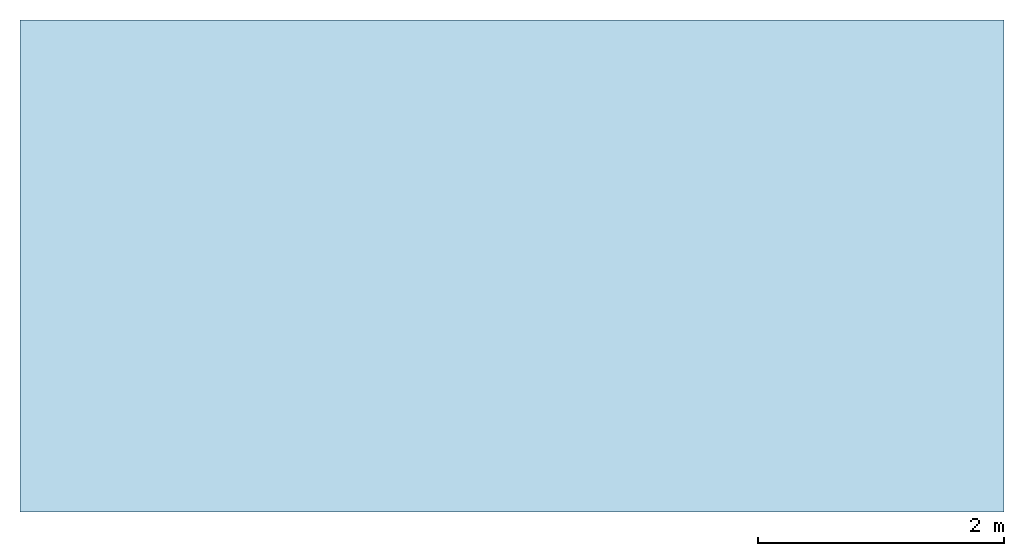
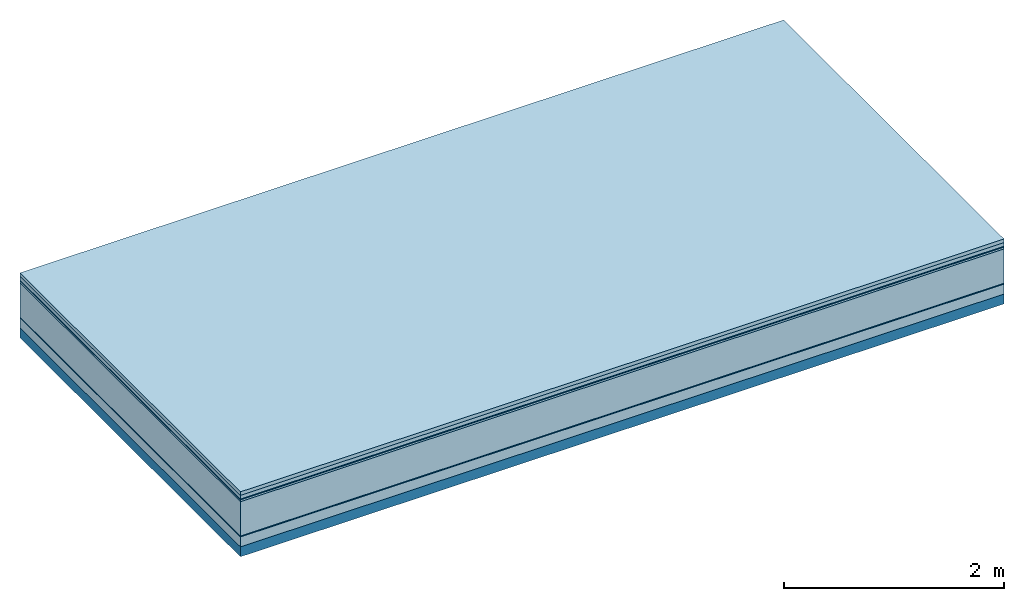
# One storey: 7 plates, 1 member, 1 element without a shape of its own.
"""IFC4 building model written with IfcOpenShell, lengths in metres."""

import ifcopenshell
import ifcopenshell.guid

model = None  # the IFC model being written
_history = None  # IfcOwnerHistory: only IFC2X3 demands one
_inside = {}  # id of a spatial element -> (the spatial element, [elements in it])
_under = {}  # id of a project, library or spatial element -> (it, [spatial elements below it])
_declared = {}  # id of a project -> (the project, [libraries it declares])
_typed = {}  # id of a type object -> (the type object, [elements of that type])
_made_of = {}  # id of a material, layer set ... -> (it, [elements and type objects made of it])


def new_model(schema):
    """Start an empty IFC model of exactly this schema.

    Asked for "IFC4X3", IfcOpenShell would pick the latest addendum, in which some entities
    have other attributes; the version numbers below select the first issue.
    IFC2X3 requires an IfcOwnerHistory on every rooted entity: one is made here for all.
    """
    global model, _history
    if schema == "IFC4X3":
        model = ifcopenshell.file(schema_version=(4, 3, 0, 0))
    else:
        model = ifcopenshell.file(schema=schema)
    _inside.clear()
    _under.clear()
    _declared.clear()
    _typed.clear()
    _made_of.clear()
    _history = None
    if model.schema == "IFC2X3":
        org = make("IfcOrganization", Name="unknown")
        user = make(
            "IfcPersonAndOrganization",
            ThePerson=make("IfcPerson", FamilyName="unknown"),
            TheOrganization=org,
        )
        app = make(
            "IfcApplication",
            ApplicationDeveloper=org,
            Version="unknown",
            ApplicationFullName="unknown",
            ApplicationIdentifier="unknown",
        )
        _history = make(
            "IfcOwnerHistory",
            OwningUser=user,
            OwningApplication=app,
            ChangeAction="ADDED",
            CreationDate=0,
        )
    return model


def make(cls, **values):
    """One entity of the class cls with the attributes given. An attribute that is None is left unset."""
    return model.create_entity(
        cls, **{name: value for name, value in values.items() if value is not None}
    )


def rooted(cls, **values):
    """An entity with a GlobalId (a new one), such as an element, a storey or a relation."""
    return make(cls, GlobalId=ifcopenshell.guid.new(), OwnerHistory=_history, **values)


def si_unit(unit_type, name, prefix=None):
    """IfcSIUnit, for example si_unit("LENGTHUNIT", "METRE", prefix="MILLI")."""
    return make("IfcSIUnit", UnitType=unit_type, Prefix=prefix, Name=name)


def derived_unit(unit_type, elements):
    """IfcDerivedUnit: a product of units, each with its exponent."""
    return make(
        "IfcDerivedUnit",
        Elements=[
            make("IfcDerivedUnitElement", Unit=unit, Exponent=power)
            for unit, power in elements
        ],
        UnitType=unit_type,
    )


def assignment(units):
    """IfcUnitAssignment: the units of a project."""
    return None if units is None else make("IfcUnitAssignment", Units=units)


def point(xyz):
    """IfcCartesianPoint."""
    return None if xyz is None else make("IfcCartesianPoint", Coordinates=xyz)


def direction(xyz):
    """IfcDirection."""
    return None if xyz is None else make("IfcDirection", DirectionRatios=xyz)


def frame(location, z_axis=None, x_axis=None):
    """IfcAxis2Placement3D, a coordinate frame: its origin and axes. An axis left out is left unset."""
    return make(
        "IfcAxis2Placement3D",
        Location=point(location),
        Axis=direction(z_axis),
        RefDirection=direction(x_axis),
    )


def frame_2d(location, x_axis=None):
    """IfcAxis2Placement2D, a coordinate frame in the plane: its origin and x axis."""
    return make(
        "IfcAxis2Placement2D", Location=point(location), RefDirection=direction(x_axis)
    )


def origin():
    """The frame at (0, 0, 0) with its axes left unset."""
    return frame((0.0, 0.0, 0.0))


def origin_with_axes():
    """The frame at (0, 0, 0) with the z axis (0, 0, 1) and the x axis (1, 0, 0) written out."""
    return frame((0.0, 0.0, 0.0), z_axis=(0.0, 0.0, 1.0), x_axis=(1.0, 0.0, 0.0))


def place(relative_to, where):
    """IfcLocalPlacement: puts the frame where relative to a parent placement (None: the world)."""
    return make(
        "IfcLocalPlacement", PlacementRelTo=relative_to, RelativePlacement=where
    )


def context(
    kind, dimensions, precision=None, world=None, true_north=None, identifier=None
):
    """IfcGeometricRepresentationContext, for example the 3D "Model" context."""
    return make(
        "IfcGeometricRepresentationContext",
        ContextIdentifier=identifier,
        ContextType=kind,
        CoordinateSpaceDimension=dimensions,
        Precision=precision,
        WorldCoordinateSystem=world,
        TrueNorth=true_north,
    )


def project(units=None, contexts=None):
    """IfcProject with its units and contexts."""
    return rooted(
        "IfcProject",
        Name="project",
        RepresentationContexts=contexts,
        UnitsInContext=assignment(units),
    )


def spatial(cls, under=None, at=None, **own):
    """A site, building, storey or space (cls), placed at a placement, below another one or the project."""
    s = rooted(cls, ObjectPlacement=at, **own)
    if under is not None:
        _under.setdefault(under.id(), (under, []))[1].append(s)
    return s


def profile(cls, at=None, kind="AREA", **sizes):
    """A parametric profile (cls). Its sizes go by their IFC names, for example OverallWidth=200.0."""
    return make(cls, ProfileType=kind, Position=at, **sizes)


def rectangle(**sizes):
    """IfcRectangleProfileDef."""
    return profile("IfcRectangleProfileDef", **sizes)


def extrude(swept, where, along, depth):
    """IfcExtrudedAreaSolid: the profile swept, set in the frame where, extruded along a direction by depth."""
    return make(
        "IfcExtrudedAreaSolid",
        SweptArea=swept,
        Position=where,
        ExtrudedDirection=direction(along),
        Depth=depth,
    )


def shape(context_of_items, identifier, shape_type, items):
    """IfcShapeRepresentation: the items that make up one representation, for example the "Body"."""
    return make(
        "IfcShapeRepresentation",
        ContextOfItems=context_of_items,
        RepresentationIdentifier=identifier,
        RepresentationType=shape_type,
        Items=items,
    )


def material(Name=None, Category=None):
    """IfcMaterial."""
    return make("IfcMaterial", Name=Name, Category=Category)


def layer(
    of_material, thickness, ventilated=None, Name=None, Category=None, Priority=None
):
    """IfcMaterialLayer: one layer of a wall or slab, of a material (None: an air gap)."""
    return make(
        "IfcMaterialLayer",
        Material=of_material,
        LayerThickness=thickness,
        IsVentilated=ventilated,
        Name=Name,
        Category=Category,
        Priority=Priority,
    )


def layer_set(layers, Name=None):
    """IfcMaterialLayerSet."""
    return make("IfcMaterialLayerSet", MaterialLayers=layers, LayerSetName=Name)


def made_of(thing, what):
    """Note that an element or type object is made of a material, layer set ...; save() writes the relation."""
    if what is not None:
        _made_of.setdefault(what.id(), (what, []))[1].append(thing)
    return thing


def type_object(cls, material=None, **own):
    """A type object (cls), such as IfcWallType, which elements share."""
    return made_of(rooted(cls, **own), material)


def element(
    cls,
    number,
    at=None,
    inside=None,
    cuts=None,
    type_object=None,
    material=None,
    context=None,
    identifier="Body",
    shape_type=None,
    held_by="IfcProductDefinitionShape",
    body=None,
    shapes=None,
    **own,
):
    """One element of the class cls, such as IfcWall. Its Tag is "e" and its number.

    at: its placement. inside: the storey or other place that contains it. cuts: it is an
    opening in that element (IfcRelVoidsElement). A single representation is given by context,
    identifier, shape_type and body (its items); several are given by shapes. held_by: the class
    of the entity that holds the representations. save() writes the other relations.
    """
    e = rooted(cls, Tag="e%d" % number, ObjectPlacement=at, **own)
    if body is not None:
        shapes = [shape(context, identifier, shape_type, body)]
    if shapes is not None:
        e.Representation = make(held_by, Representations=shapes)
    if inside is not None:
        _inside.setdefault(inside.id(), (inside, []))[1].append(e)
    if cuts is not None:
        rooted(
            "IfcRelVoidsElement", RelatingBuildingElement=cuts, RelatedOpeningElement=e
        )
    if type_object is not None:
        _typed.setdefault(type_object.id(), (type_object, []))[1].append(e)
    return made_of(e, material)


def aggregate(whole, parts):
    """IfcRelAggregates: a whole, such as a stair, and the parts it consists of."""
    return rooted("IfcRelAggregates", RelatingObject=whole, RelatedObjects=parts)


def save(model, path):
    """Write the relations noted so far, then the file.

    IfcRelAggregates (storeys below a building ...), IfcRelContainedInSpatialStructure (elements
    in a storey), IfcRelDefinesByType, IfcRelAssociatesMaterial and IfcRelDeclares: one each for
    every whole, place, type object, material and project.
    """
    for whole, parts in _under.values():
        aggregate(whole, parts)
    for where, things in _inside.values():
        rooted(
            "IfcRelContainedInSpatialStructure",
            RelatedElements=things,
            RelatingStructure=where,
        )
    for kind, things in _typed.values():
        rooted("IfcRelDefinesByType", RelatedObjects=things, RelatingType=kind)
    for what, things in _made_of.values():
        rooted("IfcRelAssociatesMaterial", RelatedObjects=things, RelatingMaterial=what)
    for by, libraries in _declared.values():
        rooted("IfcRelDeclares", RelatingContext=by, RelatedDefinitions=libraries)
    model.write(path)


model = new_model("IFC4")

# Units and contexts
plan_context = context("Plan", 3, precision=1e-05, world=origin(), true_north=direction((0.0, 1.0)))
model_context = context("Model", 3, precision=1e-05, world=origin(), true_north=direction((0.0, 1.0)))
ifc_project = project(units=[si_unit("LENGTHUNIT", "METRE"), derived_unit("SOUNDPRESSUREUNIT", [(si_unit("PRESSUREUNIT", "PASCAL", prefix="MICRO"), 0)]), si_unit("ENERGYUNIT", "JOULE", prefix="MEGA"), si_unit("MASSUNIT", "GRAM", prefix="KILO"), derived_unit("THERMALTRANSMITTANCEUNIT", [(si_unit("POWERUNIT", "WATT"), 1), (si_unit("AREAUNIT", "SQUARE_METRE"), -1), (si_unit("THERMODYNAMICTEMPERATUREUNIT", "KELVIN"), -1)]), derived_unit("AREADENSITYUNIT", [(si_unit("MASSUNIT", "GRAM", prefix="KILO"), 1), (si_unit("AREAUNIT", "SQUARE_METRE"), -1)]), derived_unit("USERDEFINED", [(si_unit("ENERGYUNIT", "JOULE", prefix="MEGA"), 1), (si_unit("AREAUNIT", "SQUARE_METRE"), -1)])], contexts=[plan_context, model_context])

# Site, building, storey
site = spatial("IfcSite", under=ifc_project)
building_placement = place(None, origin())
building = spatial("IfcBuilding", under=site, at=building_placement)
storey_placement = place(building_placement, origin())
storey = spatial("IfcBuildingStorey", under=building, at=storey_placement)

# Slab, member, plates
ifc_material_1 = material(Name="Garden plates", Category="02.007")
ifc_layer_1 = layer(ifc_material_1, 0.04, Name="Use and protection layer 3")
ifc_material_2 = material(Name="Gravel 8-16mm", Category="03.011")
ifc_layer_2 = layer(ifc_material_2, 0.04, Name="Use and protection layer 2")
ifc_material_3 = material(Name="Protective layer", Category="09.007")
ifc_layer_3 = layer(ifc_material_3, 0.01, Name="Use and protection layer 1")
ifc_material_4 = material(Name="Bituminous", Category="09.003")
ifc_layer_4 = layer(ifc_material_4, 0.02, Name="Seal")
ifc_material_5 = material(Name="Mineral wool", Category="10.008")
ifc_layer_5 = layer(ifc_material_5, 0.38, Name="Exterior insulation layer 1")
ifc_material_6 = material(Name="Vapor-permeable barrier", Category="09.006")
ifc_layer_6 = layer(ifc_material_6, 0.01, Name="layer / temporary roof")
ifc_material_7 = material(Category="01.002")
ifc_layer_7 = layer(ifc_material_7, 0.11, Name="above 1st layer")
ifc_material_8 = material(Name="Rigid, of the art")
ifc_layer_8 = layer(ifc_material_8, 0.0, Name="Bond")
ifc_layer_9 = layer(None, 0.11, Name="Support")
ifc_layer_set = layer_set([ifc_layer_1, ifc_layer_2, ifc_layer_3, ifc_layer_4, ifc_layer_5, ifc_layer_6, ifc_layer_7, ifc_layer_8, ifc_layer_9])
slab_type = type_object("IfcSlabType", Name="F0087", PredefinedType="NOTDEFINED", material=ifc_layer_set)
slab_placement = place(None, frame((0.0, 0.0, 0.0), z_axis=(0.0, 0.0, -1.0), x_axis=(1.0, 0.0, 0.0)))
slab = element("IfcSlab", 1, at=slab_placement, inside=storey, type_object=slab_type, material=ifc_layer_set, Name="Slab #1")
ifc_material_9 = material(Name="Solid timber panel")
member_placement = place(slab_placement, origin())
member = element("IfcMember", 2, at=member_placement, material=ifc_material_9, Name="Support", context=plan_context, shape_type="SweptSolid", body=[
    extrude(rectangle(XDim=1.0, YDim=0.11, at=frame_2d((0.5, 0.055), x_axis=(1.0, 0.0))), frame((0.0, 4.0, 0.61), z_axis=(0.0, -1.0, 0.0), x_axis=(1.0, 0.0, 0.0)), (0.0, 0.0, 1.0), 4.0),
    extrude(rectangle(XDim=1.0, YDim=0.11, at=frame_2d((0.5, 0.055), x_axis=(1.0, 0.0))), frame((1.0, 4.0, 0.61), z_axis=(0.0, -1.0, 0.0), x_axis=(1.0, 0.0, 0.0)), (0.0, 0.0, 1.0), 4.0),
    extrude(rectangle(XDim=1.0, YDim=0.11, at=frame_2d((0.5, 0.055), x_axis=(1.0, 0.0))), frame((2.0, 4.0, 0.61), z_axis=(0.0, -1.0, 0.0), x_axis=(1.0, 0.0, 0.0)), (0.0, 0.0, 1.0), 4.0),
    extrude(rectangle(XDim=1.0, YDim=0.11, at=frame_2d((0.5, 0.055), x_axis=(1.0, 0.0))), frame((3.0, 4.0, 0.61), z_axis=(0.0, -1.0, 0.0), x_axis=(1.0, 0.0, 0.0)), (0.0, 0.0, 1.0), 4.0),
    extrude(rectangle(XDim=1.0, YDim=0.11, at=frame_2d((0.5, 0.055), x_axis=(1.0, 0.0))), frame((4.0, 4.0, 0.61), z_axis=(0.0, -1.0, 0.0), x_axis=(1.0, 0.0, 0.0)), (0.0, 0.0, 1.0), 4.0),
    extrude(rectangle(XDim=1.0, YDim=0.11, at=frame_2d((0.5, 0.055), x_axis=(1.0, 0.0))), frame((5.0, 4.0, 0.61), z_axis=(0.0, -1.0, 0.0), x_axis=(1.0, 0.0, 0.0)), (0.0, 0.0, 1.0), 4.0),
    extrude(rectangle(XDim=1.0, YDim=0.11, at=frame_2d((0.5, 0.055), x_axis=(1.0, 0.0))), frame((6.0, 4.0, 0.61), z_axis=(0.0, -1.0, 0.0), x_axis=(1.0, 0.0, 0.0)), (0.0, 0.0, 1.0), 4.0),
    extrude(rectangle(XDim=1.0, YDim=0.11, at=frame_2d((0.5, 0.055), x_axis=(1.0, 0.0))), frame((7.0, 4.0, 0.61), z_axis=(0.0, -1.0, 0.0), x_axis=(1.0, 0.0, 0.0)), (0.0, 0.0, 1.0), 4.0),
])
plate_1_placement = place(slab_placement, origin())
plate_1 = element("IfcPlate", 3, at=plate_1_placement, material=ifc_material_1, Name="Use and protection layer 3", context=plan_context, shape_type="SweptSolid", body=[
    extrude(rectangle(XDim=8.0, YDim=4.0, at=frame_2d((4.0, 2.0), x_axis=(1.0, 0.0))), origin_with_axes(), (0.0, 0.0, 1.0), 0.04),
])
plate_2_placement = place(slab_placement, origin())
plate_2 = element("IfcPlate", 4, at=plate_2_placement, material=ifc_material_2, Name="Use and protection layer 2", context=plan_context, shape_type="SweptSolid", body=[
    extrude(rectangle(XDim=8.0, YDim=4.0, at=frame_2d((4.0, 2.0), x_axis=(1.0, 0.0))), frame((0.0, 0.0, 0.04), z_axis=(0.0, 0.0, 1.0), x_axis=(1.0, 0.0, 0.0)), (0.0, 0.0, 1.0), 0.04),
])
plate_3_placement = place(slab_placement, origin())
plate_3 = element("IfcPlate", 5, at=plate_3_placement, material=ifc_material_3, Name="Use and protection layer 1", context=plan_context, shape_type="SweptSolid", body=[
    extrude(rectangle(XDim=8.0, YDim=4.0, at=frame_2d((4.0, 2.0), x_axis=(1.0, 0.0))), frame((0.0, 0.0, 0.08), z_axis=(0.0, 0.0, 1.0), x_axis=(1.0, 0.0, 0.0)), (0.0, 0.0, 1.0), 0.01),
])
plate_4_placement = place(slab_placement, origin())
plate_4 = element("IfcPlate", 6, at=plate_4_placement, material=ifc_material_4, Name="Seal", context=plan_context, shape_type="SweptSolid", body=[
    extrude(rectangle(XDim=8.0, YDim=4.0, at=frame_2d((4.0, 2.0), x_axis=(1.0, 0.0))), frame((0.0, 0.0, 0.09), z_axis=(0.0, 0.0, 1.0), x_axis=(1.0, 0.0, 0.0)), (0.0, 0.0, 1.0), 0.02),
])
plate_5_placement = place(slab_placement, origin())
plate_5 = element("IfcPlate", 7, at=plate_5_placement, material=ifc_material_5, Name="Exterior insulation layer 1", context=plan_context, shape_type="SweptSolid", body=[
    extrude(rectangle(XDim=8.0, YDim=4.0, at=frame_2d((4.0, 2.0), x_axis=(1.0, 0.0))), frame((0.0, 0.0, 0.11), z_axis=(0.0, 0.0, 1.0), x_axis=(1.0, 0.0, 0.0)), (0.0, 0.0, 1.0), 0.38),
])
plate_6_placement = place(slab_placement, origin())
plate_6 = element("IfcPlate", 8, at=plate_6_placement, material=ifc_material_6, Name="layer / temporary roof", context=plan_context, shape_type="SweptSolid", body=[
    extrude(rectangle(XDim=8.0, YDim=4.0, at=frame_2d((4.0, 2.0), x_axis=(1.0, 0.0))), frame((0.0, 0.0, 0.49), z_axis=(0.0, 0.0, 1.0), x_axis=(1.0, 0.0, 0.0)), (0.0, 0.0, 1.0), 0.01),
])
plate_7_placement = place(slab_placement, origin())
plate_7 = element("IfcPlate", 9, at=plate_7_placement, material=ifc_material_7, Name="above 1st layer", context=plan_context, shape_type="SweptSolid", body=[
    extrude(rectangle(XDim=8.0, YDim=4.0, at=frame_2d((4.0, 2.0), x_axis=(1.0, 0.0))), frame((0.0, 0.0, 0.5), z_axis=(0.0, 0.0, 1.0), x_axis=(1.0, 0.0, 0.0)), (0.0, 0.0, 1.0), 0.11),
])
aggregate(slab, [plate_1, plate_2, plate_3, plate_4, plate_5, plate_6, plate_7, member])

save(model, "model.ifc")
